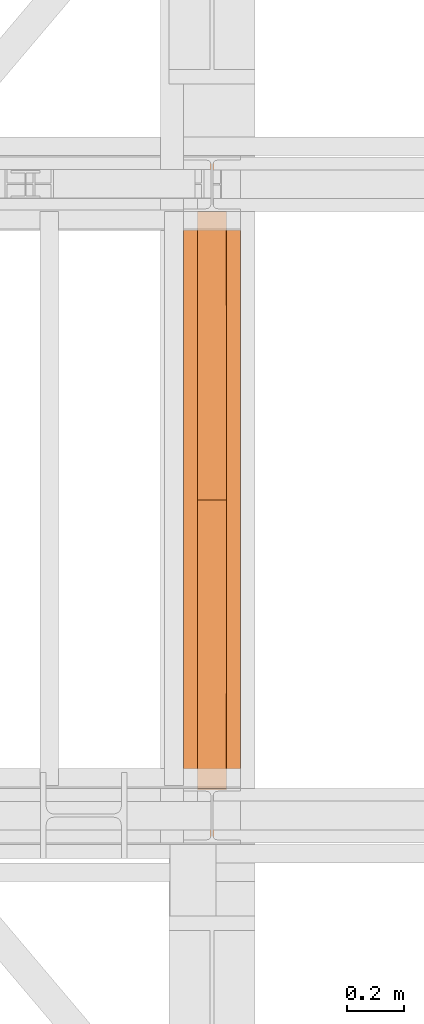
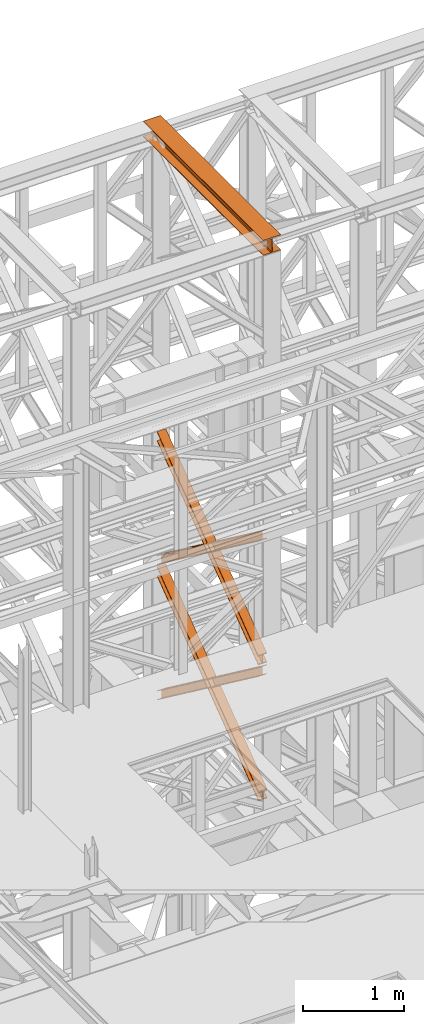
# One storey, part 157 of 208: 5 proxies.
"""IFC2X3 building model written with IfcOpenShell, lengths in millimetres."""

from ifc_helpers import new_model, entity, si_unit, converted_unit, frame, origin, origin_with_axes, place, context, subcontext, project, spatial, faceted_brep, element, save


model = new_model("IFC2X3")

# Units and contexts
model_context = context("Model", 3, precision=1e-05, world=origin())
plan_context = context("Plan", 3, precision=1e-05, world=origin())
body_context = subcontext(model_context, "Body", "Model", "MODEL_VIEW")
ifc_project = project(units=[si_unit("LENGTHUNIT", "METRE", prefix="MILLI"), converted_unit("PLANEANGLEUNIT", "DEGREE", entity("IfcPlaneAngleMeasure", 0.0174532925199433), si_unit("PLANEANGLEUNIT", "RADIAN"), dimensions=[0, 0, 0, 0, 0, 0, 0]), si_unit("AREAUNIT", "SQUARE_METRE"), si_unit("VOLUMEUNIT", "CUBIC_METRE")], contexts=[model_context, plan_context])

# Building, storey
building_placement = place(None, origin())
building = spatial("IfcBuilding", under=ifc_project, at=building_placement, CompositionType="COMPLEX")
storey_placement = place(building_placement, origin_with_axes())
storey = spatial("IfcBuildingStorey", under=building, at=storey_placement, Name="Geschoss", CompositionType="ELEMENT")

# Proxies
proxy_1_placement = place(storey_placement, frame((5393.25496703855, -16057.57439657638, 12249.99005869381), z_axis=(0.0, 0.0, 1.0), x_axis=(1.0, 0.0, 0.0)))
element("IfcBuildingElementProxy", 1, at=proxy_1_placement, inside=storey, context=body_context, shape_type="Brep", body=[
    faceted_brep([(0.01000000000021828, 2390.010012516977, 0.01000000000021828), (200.0100029802325, 2390.010012516977, 0.01000000000021828), (200.0100029802325, 2390.010012516977, 10.00999791383765), (121.2600035762789, 2390.010012516977, 10.01000536441825), (111.9441915473344, 2390.010012516977, 11.87455041170142), (105.1245498640838, 2390.010012516977, 18.69419349193595), (103.2600015571716, 2390.010012516977, 28.01000458955787), (103.2600015571716, 2390.010012516977, 162.0100153779986), (105.1245498640838, 2390.010012516977, 171.3258264756205), (111.9441915473344, 2390.010012516977, 178.145469555855), (121.2600035762789, 2390.010012516977, 180.0100146031382), (200.0100029802325, 2390.010012516977, 180.0100146031382), (200.0100029802325, 2390.010012516977, 190.0100125169756), (0.01000000000021828, 2390.010012516977, 190.0100125169756), (0.01000000000021828, 2390.010012516977, 180.0100146031382), (78.75999940395377, 2390.010012516977, 180.0100146031382), (88.07581143289826, 2390.010012516977, 178.145469555855), (94.89545311614893, 2390.010012516977, 171.3258264756205), (96.76000142306111, 2390.010012516977, 162.0100153779986), (96.76000142306111, 2390.010012516977, 28.01000458955787), (94.89545311614893, 2390.010012516977, 18.69419349193595), (88.07581143289826, 2390.010012516977, 11.87455041170142), (78.75999940395377, 2390.010012516977, 10.01000536441825), (0.01000000000021828, 2390.010012516977, 10.00999791383765), (200.0100029802325, 2390.010012516977, 0.01000000000021828), (0.01000000000021828, 2390.010012516977, 0.01000000000021828), (0.01000000000021828, 0.01000000000021828, 0.01000000000021828), (200.0100029802325, 0.01000000000021828, 0.01000000000021828), (200.0100029802325, 2390.010012516977, 10.00999791383765), (200.0100029802325, 2390.010012516977, 0.01000000000021828), (200.0100029802325, 0.01000000000021828, 0.01000000000021828), (200.0100029802325, 0.01000000000021828, 10.00999791383765), (121.2600035762789, 2390.010012516977, 10.01000536441825), (200.0100029802325, 2390.010012516977, 10.00999791383765), (200.0100029802325, 0.01000000000021828, 10.00999791383765), (121.2600035762789, 0.01000000000021828, 10.01000536441825), (111.9441915473344, 2390.010012516977, 11.87455041170142), (121.2600035762789, 2390.010012516977, 10.01000536441825), (121.2600035762789, 0.01000000000021828, 10.01000536441825), (111.9441915473344, 0.01000000000021828, 11.87455041170142), (105.1245498640838, 2390.010012516977, 18.69419349193595), (111.9441915473344, 2390.010012516977, 11.87455041170142), (111.9441915473344, 0.01000000000021828, 11.87455041170142), (105.1245498640838, 0.01000000000021828, 18.69419349193595), (103.2600015571716, 2390.010012516977, 28.01000458955787), (105.1245498640838, 2390.010012516977, 18.69419349193595), (105.1245498640838, 0.01000000000021828, 18.69419349193595), (103.2600015571716, 0.01000000000021828, 28.01000458955787), (103.2600015571716, 2390.010012516977, 162.0100153779986), (103.2600015571716, 2390.010012516977, 28.01000458955787), (103.2600015571716, 0.01000000000021828, 28.01000458955787), (103.2600015571716, 0.01000000000021828, 162.0100153779986), (105.1245498640838, 2390.010012516977, 171.3258264756205), (103.2600015571716, 2390.010012516977, 162.0100153779986), (103.2600015571716, 0.01000000000021828, 162.0100153779986), (105.1245498640838, 0.01000000000021828, 171.3258264756205), (111.9441915473344, 2390.010012516977, 178.145469555855), (105.1245498640838, 2390.010012516977, 171.3258264756205), (105.1245498640838, 0.01000000000021828, 171.3258264756205), (111.9441915473344, 0.01000000000021828, 178.145469555855), (121.2600035762789, 2390.010012516977, 180.0100146031382), (111.9441915473344, 2390.010012516977, 178.145469555855), (111.9441915473344, 0.01000000000021828, 178.145469555855), (121.2600035762789, 0.01000000000021828, 180.0100146031382), (200.0100029802325, 2390.010012516977, 180.0100146031382), (121.2600035762789, 2390.010012516977, 180.0100146031382), (121.2600035762789, 0.01000000000021828, 180.0100146031382), (200.0100029802325, 0.01000000000021828, 180.0100146031382), (200.0100029802325, 2390.010012516977, 190.0100125169756), (200.0100029802325, 2390.010012516977, 180.0100146031382), (200.0100029802325, 0.01000000000021828, 180.0100146031382), (200.0100029802325, 0.01000000000021828, 190.0100125169756), (0.01000000000021828, 2390.010012516977, 190.0100125169756), (200.0100029802325, 2390.010012516977, 190.0100125169756), (200.0100029802325, 0.01000000000021828, 190.0100125169756), (0.01000000000021828, 0.01000000000021828, 190.0100125169756), (0.01000000000021828, 2390.010012516977, 180.0100146031382), (0.01000000000021828, 2390.010012516977, 190.0100125169756), (0.01000000000021828, 0.01000000000021828, 190.0100125169756), (0.01000000000021828, 0.01000000000021828, 180.0100146031382), (78.75999940395377, 2390.010012516977, 180.0100146031382), (0.01000000000021828, 2390.010012516977, 180.0100146031382), (0.01000000000021828, 0.01000000000021828, 180.0100146031382), (78.75999940395377, 0.01000000000021828, 180.0100146031382), (88.07581143289826, 2390.010012516977, 178.145469555855), (78.75999940395377, 2390.010012516977, 180.0100146031382), (78.75999940395377, 0.01000000000021828, 180.0100146031382), (88.07581143289826, 0.01000000000021828, 178.145469555855), (94.89545311614893, 2390.010012516977, 171.3258264756205), (88.07581143289826, 2390.010012516977, 178.145469555855), (88.07581143289826, 0.01000000000021828, 178.145469555855), (94.89545311614893, 0.01000000000021828, 171.3258264756205), (96.76000142306111, 2390.010012516977, 162.0100153779986), (94.89545311614893, 2390.010012516977, 171.3258264756205), (94.89545311614893, 0.01000000000021828, 171.3258264756205), (96.76000142306111, 0.01000000000021828, 162.0100153779986), (96.76000142306111, 2390.010012516977, 28.01000458955787), (96.76000142306111, 2390.010012516977, 162.0100153779986), (96.76000142306111, 0.01000000000021828, 162.0100153779986), (96.76000142306111, 0.01000000000021828, 28.01000458955787), (94.89545311614893, 2390.010012516977, 18.69419349193595), (96.76000142306111, 2390.010012516977, 28.01000458955787), (96.76000142306111, 0.01000000000021828, 28.01000458955787), (94.89545311614893, 0.01000000000021828, 18.69419349193595), (88.07581143289826, 2390.010012516977, 11.87455041170142), (94.89545311614893, 2390.010012516977, 18.69419349193595), (94.89545311614893, 0.01000000000021828, 18.69419349193595), (88.07581143289826, 0.01000000000021828, 11.87455041170142), (78.75999940395377, 2390.010012516977, 10.01000536441825), (88.07581143289826, 2390.010012516977, 11.87455041170142), (88.07581143289826, 0.01000000000021828, 11.87455041170142), (78.75999940395377, 0.01000000000021828, 10.01000536441825), (0.01000000000021828, 2390.010012516977, 10.00999791383765), (78.75999940395377, 2390.010012516977, 10.01000536441825), (78.75999940395377, 0.01000000000021828, 10.01000536441825), (0.01000000000021828, 0.01000000000021828, 10.00999791383765), (0.01000000000021828, 2390.010012516977, 0.01000000000021828), (0.01000000000021828, 2390.010012516977, 10.00999791383765), (0.01000000000021828, 0.01000000000021828, 10.00999791383765), (0.01000000000021828, 0.01000000000021828, 0.01000000000021828), (0.01000000000021828, 0.01000000000021828, 0.01000000000021828), (0.01000000000021828, 0.01000000000021828, 10.00999791383765), (78.75999940395377, 0.01000000000021828, 10.01000536441825), (88.07581143289826, 0.01000000000021828, 11.87455041170142), (94.89545311614893, 0.01000000000021828, 18.69419349193595), (96.76000142306111, 0.01000000000021828, 28.01000458955787), (96.76000142306111, 0.01000000000021828, 162.0100153779986), (94.89545311614893, 0.01000000000021828, 171.3258264756205), (88.07581143289826, 0.01000000000021828, 178.145469555855), (78.75999940395377, 0.01000000000021828, 180.0100146031382), (0.01000000000021828, 0.01000000000021828, 180.0100146031382), (0.01000000000021828, 0.01000000000021828, 190.0100125169756), (200.0100029802325, 0.01000000000021828, 190.0100125169756), (200.0100029802325, 0.01000000000021828, 180.0100146031382), (121.2600035762789, 0.01000000000021828, 180.0100146031382), (111.9441915473344, 0.01000000000021828, 178.145469555855), (105.1245498640838, 0.01000000000021828, 171.3258264756205), (103.2600015571716, 0.01000000000021828, 162.0100153779986), (103.2600015571716, 0.01000000000021828, 28.01000458955787), (105.1245498640838, 0.01000000000021828, 18.69419349193595), (111.9441915473344, 0.01000000000021828, 11.87455041170142), (121.2600035762789, 0.01000000000021828, 10.01000536441825), (200.0100029802325, 0.01000000000021828, 10.00999791383765), (200.0100029802325, 0.01000000000021828, 0.01000000000021828)], [[[0, 1, 2, 3, 4, 5, 6, 7, 8, 9, 10, 11, 12, 13, 14, 15, 16, 17, 18, 19, 20, 21, 22, 23]], [[24, 25, 26, 27]], [[28, 29, 30, 31]], [[32, 33, 34, 35]], [[36, 37, 38, 39]], [[40, 41, 42, 43]], [[44, 45, 46, 47]], [[48, 49, 50, 51]], [[52, 53, 54, 55]], [[56, 57, 58, 59]], [[60, 61, 62, 63]], [[64, 65, 66, 67]], [[68, 69, 70, 71]], [[72, 73, 74, 75]], [[76, 77, 78, 79]], [[80, 81, 82, 83]], [[84, 85, 86, 87]], [[88, 89, 90, 91]], [[92, 93, 94, 95]], [[96, 97, 98, 99]], [[100, 101, 102, 103]], [[104, 105, 106, 107]], [[108, 109, 110, 111]], [[112, 113, 114, 115]], [[116, 117, 118, 119]], [[120, 121, 122, 123, 124, 125, 126, 127, 128, 129, 130, 131, 132, 133, 134, 135, 136, 137, 138, 139, 140, 141, 142, 143]]], orient=[[False], [False], [False], [False], [False], [False], [False], [False], [False], [False], [False], [False], [False], [False], [False], [False], [False], [False], [False], [False], [False], [False], [False], [False], [False], [False]]),
])
proxy_2_placement = place(storey_placement, frame((5443.082798491103, -15873.1965123697, 5499.689768811883), z_axis=(0.0, 0.0, 1.0), x_axis=(1.0, 0.0, 0.0)))
element("IfcBuildingElementProxy", 2, at=proxy_2_placement, inside=storey, context=body_context, shape_type="Brep", body=[
    faceted_brep([(100.0229428112289, 2015.632115793322, 1505.703241650141), (100.1858455764686, 1.953628280809426, 0.02100513656296243), (100.1847800613887, 1.791659257409265, 9.702984703128095), (100.0218641931642, 2015.632115793322, 1515.50632986583), (0.02294341679771605, 2015.632115793322, 1505.692236513578), (0.1858461820338562, 1.953628280809426, 0.01000000000021828), (100.1858455764686, 1.953628280809426, 0.02100513656296243), (100.0229428112289, 2015.632115793322, 1505.703241650141), (0.02186479873125791, 2015.632115793322, 1515.495324729271), (0.1847806669538841, 1.791659257407446, 9.691979566568989), (0.1858461820338562, 1.953628280809426, 0.01000000000021828), (0.02294341679771605, 2015.632115793322, 1505.692236513578), (47.52186451108355, 2015.632115793322, 1515.500552169136), (47.68478037930981, 1.791659257407446, 9.697207006434837), (0.1847806669538841, 1.791659257407446, 9.691979566568989), (0.02186479873125791, 2015.632115793322, 1515.495324729271), (47.51107833042624, 2015.632115793322, 1613.531434326045), (47.67412522851737, 0.1719690234003792, 106.517002672068), (47.68478037930981, 1.791659257407446, 9.697207006434837), (47.52186451108355, 2015.632115793322, 1515.500552169136), (0.01107861806849542, 2015.632115793322, 1613.526206886179), (0.174125516157801, 0.1719690234003792, 106.5117752322021), (47.67412522851737, 0.1719690234003792, 106.517002672068), (47.51107833042624, 2015.632115793322, 1613.531434326045), (0.01000000000021828, 2015.632115793322, 1623.329295101868), (0.1730600010778289, 0.01000000000021828, 116.1937547987636), (0.174125516157801, 0.1719690234003792, 106.5117752322021), (0.01107861806849542, 2015.632115793322, 1613.526206886179), (100.0099993944386, 2015.632115793322, 1623.340300238435), (100.1730593955126, 0.01000000000203727, 116.2047599353264), (0.1730600010778289, 0.01000000000021828, 116.1937547987636), (0.01000000000021828, 2015.632115793322, 1623.329295101868), (100.0110780125051, 2015.632115793322, 1613.537212022739), (100.1741249105908, 0.1719690234003792, 106.5227803687612), (100.1730593955126, 0.01000000000203727, 116.2047599353264), (100.0099993944386, 2015.632115793322, 1623.340300238435), (52.51107830014917, 2015.632115793322, 1613.531984582873), (52.67412519823665, 0.1719690234003792, 106.5175529288954), (100.1741249105908, 0.1719690234003792, 106.5227803687612), (100.0110780125051, 2015.632115793322, 1613.537212022739), (52.52186448080829, 2015.632115793322, 1515.501102425964), (52.68478034903274, 1.791659257409265, 9.697757263262247), (52.67412519823665, 0.1719690234003792, 106.5175529288954), (52.51107830014917, 2015.632115793322, 1613.531984582873), (100.0218641931642, 2015.632115793322, 1515.50632986583), (100.1847800613887, 1.791659257409265, 9.702984703128095), (52.68478034903274, 1.791659257409265, 9.697757263262247), (52.52186448080829, 2015.632115793322, 1515.501102425964), (100.1858455764686, 1.953628280809426, 0.02100513656296243), (0.1858461820338562, 1.953628280809426, 0.01000000000021828), (0.1847806669538841, 1.791659257407446, 9.691979566568989), (47.68478037930981, 1.791659257407446, 9.697207006434837), (47.67412522851737, 0.1719690234003792, 106.517002672068), (0.174125516157801, 0.1719690234003792, 106.5117752322021), (0.1730600010778289, 0.01000000000021828, 116.1937547987636), (100.1730593955126, 0.01000000000203727, 116.2047599353264), (100.1741249105908, 0.1719690234003792, 106.5227803687612), (52.67412519823665, 0.1719690234003792, 106.5175529288954), (52.68478034903274, 1.791659257409265, 9.697757263262247), (100.1847800613887, 1.791659257409265, 9.702984703128095), (100.0218641931642, 2015.632115793322, 1515.50632986583), (52.52186448080829, 2015.632115793322, 1515.501102425964), (52.51107830014917, 2015.632115793322, 1613.531984582873), (100.0110780125051, 2015.632115793322, 1613.537212022739), (100.0099993944386, 2015.632115793322, 1623.340300238435), (0.01000000000021828, 2015.632115793322, 1623.329295101868), (0.01107861806849542, 2015.632115793322, 1613.526206886179), (47.51107833042624, 2015.632115793322, 1613.531434326045), (47.52186451108355, 2015.632115793322, 1515.500552169136), (0.02186479873125791, 2015.632115793322, 1515.495324729271), (0.02294341679771605, 2015.632115793322, 1505.692236513578), (100.0229428112289, 2015.632115793322, 1505.703241650141)], [[[0, 1, 2, 3]], [[4, 5, 6, 7]], [[8, 9, 10, 11]], [[12, 13, 14, 15]], [[16, 17, 18, 19]], [[20, 21, 22, 23]], [[24, 25, 26, 27]], [[28, 29, 30, 31]], [[32, 33, 34, 35]], [[36, 37, 38, 39]], [[40, 41, 42, 43]], [[44, 45, 46, 47]], [[48, 49, 50, 51, 52, 53, 54, 55, 56, 57, 58, 59]], [[60, 61, 62, 63, 64, 65, 66, 67, 68, 69, 70, 71]]], orient=[[False], [False], [False], [False], [False], [False], [False], [False], [False], [False], [False], [False], [False], [False]]),
])
proxy_3_placement = place(storey_placement, frame((5443.082676642578, -15867.5743840594, 5504.219540188055), z_axis=(0.0, 0.0, 1.0), x_axis=(1.0, 0.0, 0.0)))
element("IfcBuildingElementProxy", 3, at=proxy_3_placement, inside=storey, context=body_context, shape_type="Brep", body=[
    faceted_brep([(100.0218596475406, 0.01000000000021828, 1511.076608371926), (100.1844513161013, 2010.009987483025, 9.820176864343011), (100.1855295209298, 2010.009987483025, 0.02100513655932446), (100.0229378523673, 0.01000000000021828, 1501.277436644132), (100.0229378523673, 0.01000000000021828, 1501.277436644132), (100.1855295209298, 2010.009987483025, 0.02100513655932446), (0.1855301264913578, 2010.009987483025, 0.01000000000021828), (0.02293845793246874, 0.01000000000021828, 1501.266431507576), (0.02293845793246874, 0.01000000000021828, 1501.266431507576), (0.1855301264913578, 2010.009987483025, 0.01000000000021828), (0.1844519216665503, 2010.009987483025, 9.809171727787543), (0.02186025310402329, 0.01000000000021828, 1511.06560323536), (0.02186025310402329, 0.01000000000021828, 1511.06560323536), (0.1844519216665503, 2010.009987483025, 9.809171727787543), (47.6844516340243, 2010.009987483025, 9.814399167646116), (47.52185996546359, 0.01000000000021828, 1511.070830675226), (47.52185996546359, 0.01000000000021828, 1511.070830675226), (47.6844516340243, 2010.009987483025, 9.814399167646116), (47.6736695857453, 2010.009987483025, 107.8061164454975), (47.51107791718459, 0.01000000000021828, 1609.062547953077), (47.51107791718459, 0.01000000000021828, 1609.062547953077), (47.6736695857453, 2010.009987483025, 107.8061164454975), (0.1736698733893718, 2010.009987483025, 107.8008890056317), (0.01107820482866373, 0.01000000000021828, 1609.057320513211), (0.01107820482866373, 0.01000000000021828, 1609.057320513211), (0.1736698733893718, 2010.009987483025, 107.8008890056317), (0.1725916685609263, 2010.009987483025, 117.6000607334227), (0.01000000000021828, 0.01000000000021828, 1618.856492240995), (0.01000000000021828, 0.01000000000021828, 1618.856492240995), (0.1725916685609263, 2010.009987483025, 117.6000607334227), (100.1725910629975, 2010.009987483025, 117.6110658699781), (100.009999394435, 0.01000000000021828, 1618.867497377558), (100.009999394435, 0.01000000000021828, 1618.867497377558), (100.1725910629975, 2010.009987483025, 117.6110658699781), (100.1736692678242, 2010.009987483025, 107.8118941421981), (100.0110775992634, 0.01000000000021828, 1609.068325649774), (100.0110775992634, 0.01000000000021828, 1609.068325649774), (100.1736692678242, 2010.009987483025, 107.8118941421981), (52.67366955546459, 2010.009987483025, 107.806666702325), (52.51107788690388, 0.01000000000021828, 1609.063098209905), (52.51107788690388, 0.01000000000021828, 1609.063098209905), (52.67366955546459, 2010.009987483025, 107.806666702325), (52.6844516037454, 2010.009987483025, 9.814949424477163), (52.52185993518287, 0.01000000000021828, 1511.071380932057), (52.52185993518287, 0.01000000000021828, 1511.071380932057), (52.6844516037454, 2010.009987483025, 9.814949424477163), (100.1844513161013, 2010.009987483025, 9.820176864343011), (100.0218596475406, 0.01000000000021828, 1511.076608371926), (100.1844513161013, 2010.009987483025, 9.820176864343011), (52.6844516037454, 2010.009987483025, 9.814949424477163), (52.67366955546459, 2010.009987483025, 107.806666702325), (100.1736692678242, 2010.009987483025, 107.8118941421981), (100.1725910629975, 2010.009987483025, 117.6110658699781), (0.1725916685609263, 2010.009987483025, 117.6000607334227), (0.1736698733893718, 2010.009987483025, 107.8008890056317), (47.6736695857453, 2010.009987483025, 107.8061164454975), (47.6844516340243, 2010.009987483025, 9.814399167646116), (0.1844519216665503, 2010.009987483025, 9.809171727787543), (0.1855301264913578, 2010.009987483025, 0.01000000000021828), (100.1855295209298, 2010.009987483025, 0.02100513655932446), (100.0229378523673, 0.01000000000021828, 1501.277436644132), (0.02293845793246874, 0.01000000000021828, 1501.266431507576), (0.02186025310402329, 0.01000000000021828, 1511.06560323536), (47.52185996546359, 0.01000000000021828, 1511.070830675226), (47.51107791718459, 0.01000000000021828, 1609.062547953077), (0.01107820482866373, 0.01000000000021828, 1609.057320513211), (0.01000000000021828, 0.01000000000021828, 1618.856492240995), (100.009999394435, 0.01000000000021828, 1618.867497377558), (100.0110775992634, 0.01000000000021828, 1609.068325649774), (52.51107788690388, 0.01000000000021828, 1609.063098209905), (52.52185993518287, 0.01000000000021828, 1511.071380932057), (100.0218596475406, 0.01000000000021828, 1511.076608371926)], [[[0, 1, 2, 3]], [[4, 5, 6, 7]], [[8, 9, 10, 11]], [[12, 13, 14, 15]], [[16, 17, 18, 19]], [[20, 21, 22, 23]], [[24, 25, 26, 27]], [[28, 29, 30, 31]], [[32, 33, 34, 35]], [[36, 37, 38, 39]], [[40, 41, 42, 43]], [[44, 45, 46, 47]], [[48, 49, 50, 51, 52, 53, 54, 55, 56, 57, 58, 59]], [[60, 61, 62, 63, 64, 65, 66, 67, 68, 69, 70, 71]]], orient=[[False], [False], [False], [False], [False], [False], [False], [False], [False], [False], [False], [False], [False], [False]]),
])
proxy_4_placement = place(storey_placement, frame((5442.895475356376, -15867.5743840594, 7147.441290649187), z_axis=(0.0, 0.0, 1.0), x_axis=(1.0, 0.0, 0.0)))
element("IfcBuildingElementProxy", 4, at=proxy_4_placement, inside=storey, context=body_context, shape_type="Brep", body=[
    faceted_brep([(100.0218623025612, 0.01000000000021828, 1512.063556389601), (100.1844166626906, 2010.009987483025, 9.822513400360549), (100.1854951088862, 2010.009987483025, 0.02100513655932446), (100.022940748755, 0.01000000000021828, 1502.262048125804), (100.022940748755, 0.01000000000021828, 1502.262048125804), (100.1854951088862, 2010.009987483025, 0.02100513655932446), (0.1854957144514629, 2010.009987483025, 0.01000000000021828), (0.02294135431839095, 0.01000000000021828, 1502.251042989237), (0.02294135431839095, 0.01000000000021828, 1502.251042989237), (0.1854957144514629, 2010.009987483025, 0.01000000000021828), (0.1844172682558565, 2010.009987483025, 9.811508263797805), (0.02186290812642255, 0.01000000000021828, 1512.052551253039), (0.02186290812642255, 0.01000000000021828, 1512.052551253039), (0.1844172682558565, 2010.009987483025, 9.811508263797805), (47.68441698061361, 2010.009987483025, 9.816735703663653), (47.52186262048235, 0.01000000000021828, 1512.057778692908), (47.52186262048235, 0.01000000000021828, 1512.057778692908), (47.68441698061361, 2010.009987483025, 9.816735703663653), (47.67363251868483, 2010.009987483025, 107.8318183416577), (47.51107815855175, 0.01000000000021828, 1610.072861330906), (47.51107815855175, 0.01000000000021828, 1610.072861330906), (47.67363251868483, 2010.009987483025, 107.8318183416577), (0.1736328063252586, 2010.009987483025, 107.8265909017955), (0.01107844619582465, 0.01000000000021828, 1610.067633891033), (0.01107844619582465, 0.01000000000021828, 1610.067633891033), (0.1736328063252586, 2010.009987483025, 107.8265909017955), (0.1725543601314712, 2010.009987483025, 117.6280991655931), (0.01000000000021828, 0.01000000000021828, 1619.86914215483), (0.01000000000021828, 0.01000000000021828, 1619.86914215483), (0.1725543601314712, 2010.009987483025, 117.6280991655931), (100.1725537545663, 2010.009987483025, 117.6391043021558), (100.009999394435, 0.01000000000021828, 1619.880147291397), (100.009999394435, 0.01000000000021828, 1619.880147291397), (100.1725537545663, 2010.009987483025, 117.6391043021558), (100.1736322007619, 2010.009987483025, 107.8375960383546), (100.0110778406306, 0.01000000000021828, 1610.078639027603), (100.0110778406306, 0.01000000000021828, 1610.078639027603), (100.1736322007619, 2010.009987483025, 107.8375960383546), (52.67363248840411, 2010.009987483025, 107.8323685984888), (52.51107812827468, 0.01000000000021828, 1610.073411587733), (52.51107812827468, 0.01000000000021828, 1610.073411587733), (52.67363248840411, 2010.009987483025, 107.8323685984888), (52.68441695033471, 2010.009987483025, 9.817285960491063), (52.52186259020346, 0.01000000000021828, 1512.058328949732), (52.52186259020346, 0.01000000000021828, 1512.058328949732), (52.68441695033471, 2010.009987483025, 9.817285960491063), (100.1844166626906, 2010.009987483025, 9.822513400360549), (100.0218623025612, 0.01000000000021828, 1512.063556389601), (100.1844166626906, 2010.009987483025, 9.822513400360549), (52.68441695033471, 2010.009987483025, 9.817285960491063), (52.67363248840411, 2010.009987483025, 107.8323685984888), (100.1736322007619, 2010.009987483025, 107.8375960383546), (100.1725537545663, 2010.009987483025, 117.6391043021558), (0.1725543601314712, 2010.009987483025, 117.6280991655931), (0.1736328063252586, 2010.009987483025, 107.8265909017955), (47.67363251868483, 2010.009987483025, 107.8318183416577), (47.68441698061361, 2010.009987483025, 9.816735703663653), (0.1844172682558565, 2010.009987483025, 9.811508263797805), (0.1854957144514629, 2010.009987483025, 0.01000000000021828), (100.1854951088862, 2010.009987483025, 0.02100513655932446), (100.022940748755, 0.01000000000021828, 1502.262048125804), (0.02294135431839095, 0.01000000000021828, 1502.251042989237), (0.02186290812642255, 0.01000000000021828, 1512.052551253039), (47.52186262048235, 0.01000000000021828, 1512.057778692908), (47.51107815855175, 0.01000000000021828, 1610.072861330906), (0.01107844619582465, 0.01000000000021828, 1610.067633891033), (0.01000000000021828, 0.01000000000021828, 1619.86914215483), (100.009999394435, 0.01000000000021828, 1619.880147291397), (100.0110778406306, 0.01000000000021828, 1610.078639027603), (52.51107812827468, 0.01000000000021828, 1610.073411587733), (52.52186259020346, 0.01000000000021828, 1512.058328949732), (100.0218623025612, 0.01000000000021828, 1512.063556389601)], [[[0, 1, 2, 3]], [[4, 5, 6, 7]], [[8, 9, 10, 11]], [[12, 13, 14, 15]], [[16, 17, 18, 19]], [[20, 21, 22, 23]], [[24, 25, 26, 27]], [[28, 29, 30, 31]], [[32, 33, 34, 35]], [[36, 37, 38, 39]], [[40, 41, 42, 43]], [[44, 45, 46, 47]], [[48, 49, 50, 51, 52, 53, 54, 55, 56, 57, 58, 59]], [[60, 61, 62, 63, 64, 65, 66, 67, 68, 69, 70, 71]]], orient=[[False], [False], [False], [False], [False], [False], [False], [False], [False], [False], [False], [False], [False], [False]]),
])
proxy_5_placement = place(storey_placement, frame((5442.895647595429, -15867.5743840594, 7147.394064575148), z_axis=(0.0, 0.0, 1.0), x_axis=(1.0, 0.0, 0.0)))
element("IfcBuildingElementProxy", 5, at=proxy_5_placement, inside=storey, context=body_context, shape_type="Brep", body=[
    faceted_brep([(100.0229386519513, 2010.009987483025, 1501.524522111415), (100.185572907496, 0.01000000000021828, 0.02100513656296243), (100.1844946360361, 0.01000000000021828, 9.82075546136366), (100.0218603804915, 2010.009987483025, 1511.324272436212), (0.02293925751655479, 2010.009987483025, 1501.513516974852), (0.185573513059353, 0.01000000000021828, 0.01000000000021828), (100.185572907496, 0.01000000000021828, 0.02100513656296243), (100.0229386519513, 2010.009987483025, 1501.524522111415), (0.02186098605488951, 2010.009987483025, 1511.313267299649), (0.1844952415995067, 0.01000000000021828, 9.809750324800916), (0.185573513059353, 0.01000000000021828, 0.01000000000021828), (0.02293925751655479, 2010.009987483025, 1501.513516974852), (47.52186069841264, 2010.009987483025, 1511.318494739518), (47.68449495395544, 0.01000000000021828, 9.814977764666764), (0.1844952415995067, 0.01000000000021828, 9.809750324800916), (0.02186098605488951, 2010.009987483025, 1511.313267299649), (47.51107798381418, 2010.009987483025, 1609.315997987507), (47.67371223936061, 0.01000000000021828, 107.8124810126556), (47.68449495395544, 0.01000000000021828, 9.814977764666764), (47.52186069841264, 2010.009987483025, 1511.318494739518), (0.01107827146006457, 2010.009987483025, 1609.310770547641), (0.1737125270028628, 0.01000000000021828, 107.8072535727861), (47.67371223936061, 0.01000000000021828, 107.8124810126556), (47.51107798381418, 2010.009987483025, 1609.315997987507), (0.01000000000021828, 2010.009987483025, 1619.110520872438), (0.1726342555448355, 0.01000000000021828, 117.6070038975868), (0.1737125270028628, 0.01000000000021828, 107.8072535727861), (0.01107827146006457, 2010.009987483025, 1609.310770547641), (100.009999394435, 2010.009987483025, 1619.121526009001), (100.1726336499778, 0.01000000000021828, 117.6180090341495), (0.1726342555448355, 0.01000000000021828, 117.6070038975868), (0.01000000000021828, 2010.009987483025, 1619.110520872438), (100.0110776658949, 2010.009987483025, 1609.321775684197), (100.1737119214376, 0.01000000000021828, 107.8182587093452), (100.1726336499778, 0.01000000000021828, 117.6180090341495), (100.009999394435, 2010.009987483025, 1619.121526009001), (52.5110779535371, 2010.009987483025, 1609.316548244331), (52.67371220908353, 0.01000000000021828, 107.8130312694793), (100.1737119214376, 0.01000000000021828, 107.8182587093452), (100.0110776658949, 2010.009987483025, 1609.321775684197), (52.52186066813374, 2010.009987483025, 1511.319044996339), (52.68449492368018, 0.01000000000021828, 9.815528021497812), (52.67371220908353, 0.01000000000021828, 107.8130312694793), (52.5110779535371, 2010.009987483025, 1609.316548244331), (100.0218603804915, 2010.009987483025, 1511.324272436212), (100.1844946360361, 0.01000000000021828, 9.82075546136366), (52.68449492368018, 0.01000000000021828, 9.815528021497812), (52.52186066813374, 2010.009987483025, 1511.319044996339), (100.185572907496, 0.01000000000021828, 0.02100513656296243), (0.185573513059353, 0.01000000000021828, 0.01000000000021828), (0.1844952415995067, 0.01000000000021828, 9.809750324800916), (47.68449495395544, 0.01000000000021828, 9.814977764666764), (47.67371223936061, 0.01000000000021828, 107.8124810126556), (0.1737125270028628, 0.01000000000021828, 107.8072535727861), (0.1726342555448355, 0.01000000000021828, 117.6070038975868), (100.1726336499778, 0.01000000000021828, 117.6180090341495), (100.1737119214376, 0.01000000000021828, 107.8182587093452), (52.67371220908353, 0.01000000000021828, 107.8130312694793), (52.68449492368018, 0.01000000000021828, 9.815528021497812), (100.1844946360361, 0.01000000000021828, 9.82075546136366), (100.0218603804915, 2010.009987483025, 1511.324272436212), (52.52186066813374, 2010.009987483025, 1511.319044996339), (52.5110779535371, 2010.009987483025, 1609.316548244331), (100.0110776658949, 2010.009987483025, 1609.321775684197), (100.009999394435, 2010.009987483025, 1619.121526009001), (0.01000000000021828, 2010.009987483025, 1619.110520872438), (0.01107827146006457, 2010.009987483025, 1609.310770547641), (47.51107798381418, 2010.009987483025, 1609.315997987507), (47.52186069841264, 2010.009987483025, 1511.318494739518), (0.02186098605488951, 2010.009987483025, 1511.313267299649), (0.02293925751655479, 2010.009987483025, 1501.513516974852), (100.0229386519513, 2010.009987483025, 1501.524522111415)], [[[0, 1, 2, 3]], [[4, 5, 6, 7]], [[8, 9, 10, 11]], [[12, 13, 14, 15]], [[16, 17, 18, 19]], [[20, 21, 22, 23]], [[24, 25, 26, 27]], [[28, 29, 30, 31]], [[32, 33, 34, 35]], [[36, 37, 38, 39]], [[40, 41, 42, 43]], [[44, 45, 46, 47]], [[48, 49, 50, 51, 52, 53, 54, 55, 56, 57, 58, 59]], [[60, 61, 62, 63, 64, 65, 66, 67, 68, 69, 70, 71]]], orient=[[False], [False], [False], [False], [False], [False], [False], [False], [False], [False], [False], [False], [False], [False]]),
])

save(model, "model.ifc")
